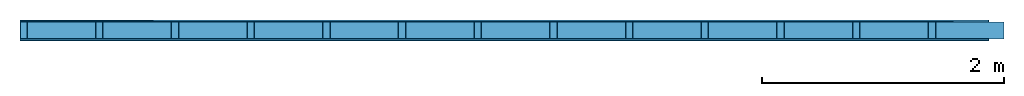
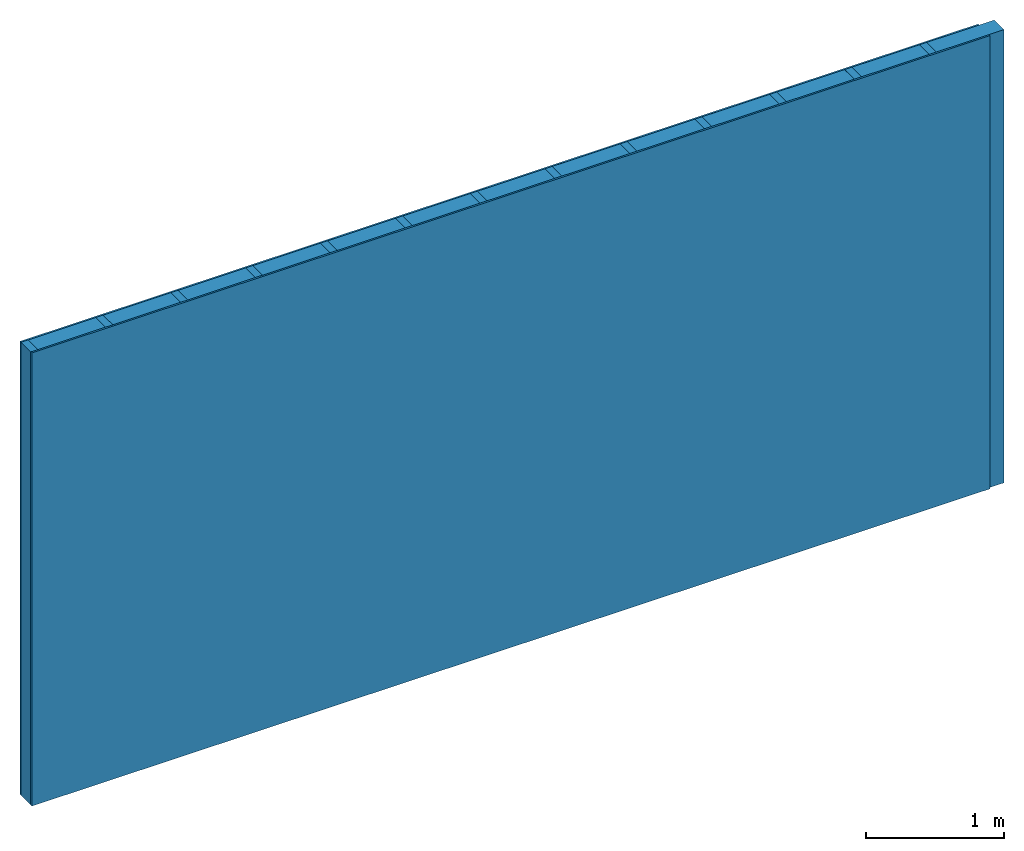
# One storey: 2 members, 2 plates, 1 element without a shape of its own.
"""IFC4 building model written with IfcOpenShell, lengths in metres."""

from ifc_helpers import new_model, si_unit, derived_unit, direction, frame, frame_2d, origin, origin_with_axes, place, context, project, spatial, rectangle, extrude, material, layer, layer_set, type_object, element, aggregate, save


model = new_model("IFC4")

# Units and contexts
plan_context = context("Plan", 3, precision=1e-05, world=origin(), true_north=direction((0.0, 1.0)))
model_context = context("Model", 3, precision=1e-05, world=origin(), true_north=direction((0.0, 1.0)))
ifc_project = project(units=[si_unit("LENGTHUNIT", "METRE"), derived_unit("SOUNDPRESSUREUNIT", [(si_unit("PRESSUREUNIT", "PASCAL", prefix="MICRO"), 0)]), si_unit("ENERGYUNIT", "JOULE", prefix="MEGA"), si_unit("MASSUNIT", "GRAM", prefix="KILO"), derived_unit("THERMALTRANSMITTANCEUNIT", [(si_unit("POWERUNIT", "WATT"), 1), (si_unit("AREAUNIT", "SQUARE_METRE"), -1), (si_unit("THERMODYNAMICTEMPERATUREUNIT", "KELVIN"), -1)]), derived_unit("AREADENSITYUNIT", [(si_unit("MASSUNIT", "GRAM", prefix="KILO"), 1), (si_unit("AREAUNIT", "SQUARE_METRE"), -1)]), derived_unit("USERDEFINED", [(si_unit("ENERGYUNIT", "JOULE", prefix="MEGA"), 1), (si_unit("AREAUNIT", "SQUARE_METRE"), -1)])], contexts=[plan_context, model_context])

# Site, building, storey
site = spatial("IfcSite", under=ifc_project)
building_placement = place(None, origin())
building = spatial("IfcBuilding", under=site, at=building_placement)
storey_placement = place(building_placement, origin())
storey = spatial("IfcBuildingStorey", under=building, at=storey_placement)

# Wall, members, plates
ifc_material_1 = material(Name="Glued joints")
ifc_layer_1 = layer(ifc_material_1, 0.0, Name="Surface")
ifc_material_2 = material(Category="03.007")
ifc_layer_2 = layer(ifc_material_2, 0.015, Name="1st layer")
ifc_material_3 = material(Name="of the art")
ifc_layer_3 = layer(ifc_material_3, 0.0, Name="Bond")
ifc_layer_4 = layer(None, 0.14, Name="Support")
ifc_layer_5 = layer(ifc_material_3, 0.0, Name="Bond")
ifc_layer_6 = layer(ifc_material_2, 0.015, Name="1st layer")
ifc_layer_7 = layer(ifc_material_1, 0.0, Name="Surface")
ifc_layer_set = layer_set([ifc_layer_1, ifc_layer_2, ifc_layer_3, ifc_layer_4, ifc_layer_5, ifc_layer_6, ifc_layer_7])
wall_type = type_object("IfcWallType", Name="C0075", PredefinedType="NOTDEFINED", material=ifc_layer_set)
wall_placement = place(None, frame((0.0, 0.0, 0.0), z_axis=(0.0, -1.0, 0.0), x_axis=(1.0, 0.0, 0.0)))
wall = element("IfcWall", 1, at=wall_placement, inside=storey, type_object=wall_type, material=ifc_layer_set, Name="Wall #1")
ifc_material_4 = material()
member_1_placement = place(wall_placement, origin())
member_1 = element("IfcMember", 2, at=member_1_placement, material=ifc_material_4, Name="Support", context=plan_context, shape_type="SweptSolid", body=[
    extrude(rectangle(XDim=0.06, YDim=0.14, at=frame_2d((0.03, 0.07), x_axis=(1.0, 0.0))), frame((0.0, 4.0, 0.015), z_axis=(0.0, -1.0, 0.0), x_axis=(1.0, 0.0, 0.0)), (0.0, 0.0, 1.0), 4.0),
    extrude(rectangle(XDim=0.06, YDim=0.14, at=frame_2d((0.03, 0.07), x_axis=(1.0, 0.0))), frame((0.625, 4.0, 0.015), z_axis=(0.0, -1.0, 0.0), x_axis=(1.0, 0.0, 0.0)), (0.0, 0.0, 1.0), 4.0),
    extrude(rectangle(XDim=0.06, YDim=0.14, at=frame_2d((0.03, 0.07), x_axis=(1.0, 0.0))), frame((1.25, 4.0, 0.015), z_axis=(0.0, -1.0, 0.0), x_axis=(1.0, 0.0, 0.0)), (0.0, 0.0, 1.0), 4.0),
    extrude(rectangle(XDim=0.06, YDim=0.14, at=frame_2d((0.03, 0.07), x_axis=(1.0, 0.0))), frame((1.875, 4.0, 0.015), z_axis=(0.0, -1.0, 0.0), x_axis=(1.0, 0.0, 0.0)), (0.0, 0.0, 1.0), 4.0),
    extrude(rectangle(XDim=0.06, YDim=0.14, at=frame_2d((0.03, 0.07), x_axis=(1.0, 0.0))), frame((2.5, 4.0, 0.015), z_axis=(0.0, -1.0, 0.0), x_axis=(1.0, 0.0, 0.0)), (0.0, 0.0, 1.0), 4.0),
    extrude(rectangle(XDim=0.06, YDim=0.14, at=frame_2d((0.03, 0.07), x_axis=(1.0, 0.0))), frame((3.125, 4.0, 0.015), z_axis=(0.0, -1.0, 0.0), x_axis=(1.0, 0.0, 0.0)), (0.0, 0.0, 1.0), 4.0),
    extrude(rectangle(XDim=0.06, YDim=0.14, at=frame_2d((0.03, 0.07), x_axis=(1.0, 0.0))), frame((3.75, 4.0, 0.015), z_axis=(0.0, -1.0, 0.0), x_axis=(1.0, 0.0, 0.0)), (0.0, 0.0, 1.0), 4.0),
    extrude(rectangle(XDim=0.06, YDim=0.14, at=frame_2d((0.03, 0.07), x_axis=(1.0, 0.0))), frame((4.375, 4.0, 0.015), z_axis=(0.0, -1.0, 0.0), x_axis=(1.0, 0.0, 0.0)), (0.0, 0.0, 1.0), 4.0),
    extrude(rectangle(XDim=0.06, YDim=0.14, at=frame_2d((0.03, 0.07), x_axis=(1.0, 0.0))), frame((5.0, 4.0, 0.015), z_axis=(0.0, -1.0, 0.0), x_axis=(1.0, 0.0, 0.0)), (0.0, 0.0, 1.0), 4.0),
    extrude(rectangle(XDim=0.06, YDim=0.14, at=frame_2d((0.03, 0.07), x_axis=(1.0, 0.0))), frame((5.625, 4.0, 0.015), z_axis=(0.0, -1.0, 0.0), x_axis=(1.0, 0.0, 0.0)), (0.0, 0.0, 1.0), 4.0),
    extrude(rectangle(XDim=0.06, YDim=0.14, at=frame_2d((0.03, 0.07), x_axis=(1.0, 0.0))), frame((6.25, 4.0, 0.015), z_axis=(0.0, -1.0, 0.0), x_axis=(1.0, 0.0, 0.0)), (0.0, 0.0, 1.0), 4.0),
    extrude(rectangle(XDim=0.06, YDim=0.14, at=frame_2d((0.03, 0.07), x_axis=(1.0, 0.0))), frame((6.875, 4.0, 0.015), z_axis=(0.0, -1.0, 0.0), x_axis=(1.0, 0.0, 0.0)), (0.0, 0.0, 1.0), 4.0),
    extrude(rectangle(XDim=0.06, YDim=0.14, at=frame_2d((0.03, 0.07), x_axis=(1.0, 0.0))), frame((7.5, 4.0, 0.015), z_axis=(0.0, -1.0, 0.0), x_axis=(1.0, 0.0, 0.0)), (0.0, 0.0, 1.0), 4.0),
])
ifc_material_5 = material()
member_2_placement = place(wall_placement, origin())
member_2 = element("IfcMember", 3, at=member_2_placement, material=ifc_material_5, Name="Cavity", context=plan_context, shape_type="SweptSolid", body=[
    extrude(rectangle(XDim=0.565, YDim=0.14, at=frame_2d((0.2825, 0.07), x_axis=(1.0, 0.0))), frame((0.06, 4.0, 0.015), z_axis=(0.0, -1.0, 0.0), x_axis=(1.0, 0.0, 0.0)), (0.0, 0.0, 1.0), 4.0),
    extrude(rectangle(XDim=0.565, YDim=0.14, at=frame_2d((0.2825, 0.07), x_axis=(1.0, 0.0))), frame((0.685, 4.0, 0.015), z_axis=(0.0, -1.0, 0.0), x_axis=(1.0, 0.0, 0.0)), (0.0, 0.0, 1.0), 4.0),
    extrude(rectangle(XDim=0.565, YDim=0.14, at=frame_2d((0.2825, 0.07), x_axis=(1.0, 0.0))), frame((1.31, 4.0, 0.015), z_axis=(0.0, -1.0, 0.0), x_axis=(1.0, 0.0, 0.0)), (0.0, 0.0, 1.0), 4.0),
    extrude(rectangle(XDim=0.565, YDim=0.14, at=frame_2d((0.2825, 0.07), x_axis=(1.0, 0.0))), frame((1.935, 4.0, 0.015), z_axis=(0.0, -1.0, 0.0), x_axis=(1.0, 0.0, 0.0)), (0.0, 0.0, 1.0), 4.0),
    extrude(rectangle(XDim=0.565, YDim=0.14, at=frame_2d((0.2825, 0.07), x_axis=(1.0, 0.0))), frame((2.56, 4.0, 0.015), z_axis=(0.0, -1.0, 0.0), x_axis=(1.0, 0.0, 0.0)), (0.0, 0.0, 1.0), 4.0),
    extrude(rectangle(XDim=0.565, YDim=0.14, at=frame_2d((0.2825, 0.07), x_axis=(1.0, 0.0))), frame((3.185, 4.0, 0.015), z_axis=(0.0, -1.0, 0.0), x_axis=(1.0, 0.0, 0.0)), (0.0, 0.0, 1.0), 4.0),
    extrude(rectangle(XDim=0.565, YDim=0.14, at=frame_2d((0.2825, 0.07), x_axis=(1.0, 0.0))), frame((3.81, 4.0, 0.015), z_axis=(0.0, -1.0, 0.0), x_axis=(1.0, 0.0, 0.0)), (0.0, 0.0, 1.0), 4.0),
    extrude(rectangle(XDim=0.565, YDim=0.14, at=frame_2d((0.2825, 0.07), x_axis=(1.0, 0.0))), frame((4.435, 4.0, 0.015), z_axis=(0.0, -1.0, 0.0), x_axis=(1.0, 0.0, 0.0)), (0.0, 0.0, 1.0), 4.0),
    extrude(rectangle(XDim=0.565, YDim=0.14, at=frame_2d((0.2825, 0.07), x_axis=(1.0, 0.0))), frame((5.06, 4.0, 0.015), z_axis=(0.0, -1.0, 0.0), x_axis=(1.0, 0.0, 0.0)), (0.0, 0.0, 1.0), 4.0),
    extrude(rectangle(XDim=0.565, YDim=0.14, at=frame_2d((0.2825, 0.07), x_axis=(1.0, 0.0))), frame((5.685, 4.0, 0.015), z_axis=(0.0, -1.0, 0.0), x_axis=(1.0, 0.0, 0.0)), (0.0, 0.0, 1.0), 4.0),
    extrude(rectangle(XDim=0.565, YDim=0.14, at=frame_2d((0.2825, 0.07), x_axis=(1.0, 0.0))), frame((6.31, 4.0, 0.015), z_axis=(0.0, -1.0, 0.0), x_axis=(1.0, 0.0, 0.0)), (0.0, 0.0, 1.0), 4.0),
    extrude(rectangle(XDim=0.565, YDim=0.14, at=frame_2d((0.2825, 0.07), x_axis=(1.0, 0.0))), frame((6.935, 4.0, 0.015), z_axis=(0.0, -1.0, 0.0), x_axis=(1.0, 0.0, 0.0)), (0.0, 0.0, 1.0), 4.0),
    extrude(rectangle(XDim=0.565, YDim=0.14, at=frame_2d((0.2825, 0.07), x_axis=(1.0, 0.0))), frame((7.56, 4.0, 0.015), z_axis=(0.0, -1.0, 0.0), x_axis=(1.0, 0.0, 0.0)), (0.0, 0.0, 1.0), 4.0),
])
plate_1_placement = place(wall_placement, origin())
plate_1 = element("IfcPlate", 4, at=plate_1_placement, material=ifc_material_2, Name="1st layer", context=plan_context, shape_type="SweptSolid", body=[
    extrude(rectangle(XDim=8.0, YDim=4.0, at=frame_2d((4.0, 2.0), x_axis=(1.0, 0.0))), origin_with_axes(), (0.0, 0.0, 1.0), 0.015),
])
plate_2_placement = place(wall_placement, origin())
plate_2 = element("IfcPlate", 5, at=plate_2_placement, material=ifc_material_2, Name="1st layer", context=plan_context, shape_type="SweptSolid", body=[
    extrude(rectangle(XDim=8.0, YDim=4.0, at=frame_2d((4.0, 2.0), x_axis=(1.0, 0.0))), frame((0.0, 0.0, 0.155), z_axis=(0.0, 0.0, 1.0), x_axis=(1.0, 0.0, 0.0)), (0.0, 0.0, 1.0), 0.015),
])
aggregate(wall, [plate_1, member_1, member_2, plate_2])

save(model, "model.ifc")
